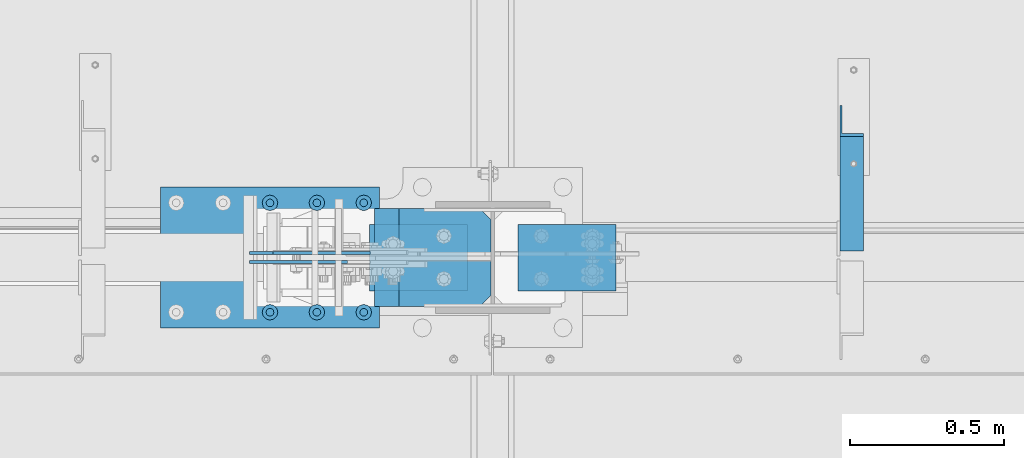
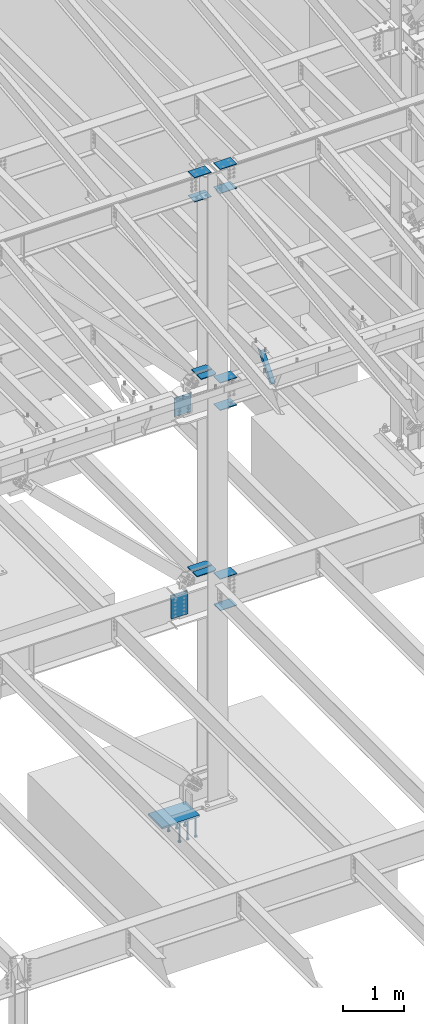
# One storey, part 841 of 1179: 22 beams, 1 member, 6 elements without a shape of their own.
"""IFC2X3 building model written with IfcOpenShell, lengths in millimetres."""

from ifc_helpers import new_model, si_unit, frame, origin_with_axes, place, context, subcontext, project, spatial, faceted_brep, material, type_object, element, aggregate, save


model = new_model("IFC2X3")

# Units and contexts
model_context = context("Model", 3, precision=1e-05, world=origin_with_axes())
body_context = subcontext(model_context, "Body", "Model", "MODEL_VIEW")
ifc_project = project(units=[si_unit("LENGTHUNIT", "METRE", prefix="MILLI"), si_unit("AREAUNIT", "SQUARE_METRE"), si_unit("VOLUMEUNIT", "CUBIC_METRE"), si_unit("MASSUNIT", "GRAM", prefix="KILO"), si_unit("TIMEUNIT", "SECOND"), si_unit("PLANEANGLEUNIT", "RADIAN"), si_unit("SOLIDANGLEUNIT", "STERADIAN"), si_unit("THERMODYNAMICTEMPERATUREUNIT", "DEGREE_CELSIUS"), si_unit("LUMINOUSINTENSITYUNIT", "LUMEN")], contexts=[model_context])

# Site, building, storey
site_placement = place(None, origin_with_axes())
site = spatial("IfcSite", under=ifc_project, at=site_placement, CompositionType="ELEMENT")
building_placement = place(site_placement, origin_with_axes())
building = spatial("IfcBuilding", under=site, at=building_placement, Name="Undefined", CompositionType="ELEMENT")
storey_placement = place(building_placement, origin_with_axes())
storey = spatial("IfcBuildingStorey", under=building, at=storey_placement, Name="Undefined", CompositionType="ELEMENT", Elevation=0.0)

# Assembly, member
assembly_1_placement = place(storey_placement, origin_with_axes())
assembly_1 = element("IfcElementAssembly", 1, at=assembly_1_placement, inside=storey, Name="ANGLE", AssemblyPlace="NOTDEFINED", PredefinedType="RIGID_FRAME")
ifc_material_1 = material(Name="STEEL/A36")
member_type = type_object("IfcMemberType", Name="L3X3X1/4", PredefinedType="NOTDEFINED")
member_placement = place(assembly_1_placement, frame((17626.0124995918, 27508.2, 8013.7), z_axis=(0.0, 0.7672237920886, -0.641379492074067), x_axis=(0.0, -0.641379492074066, -0.767223792088601)))
member = element("IfcMember", 2, at=member_placement, type_object=member_type, material=ifc_material_1, Name="ANGLE", ObjectType="L3X3X1/4", context=body_context, shape_type="Brep", body=[
    faceted_brep([(52.5421123063024, 38.0999999999985, -38.0999999999967), (-11.159141226166, 38.0999999999985, 38.1000000000095), (634.651401994255, 38.0999999999985, 38.1000000003041), (634.651401994233, 38.0999999999985, -38.0999999997293), (-11.159141226166, 31.75, 38.1000000000095), (634.651401994255, 31.75, 38.1000000003041), (47.2336745119283, 31.75, -31.7499999999982), (634.651401994237, 31.75, -31.7499999997272), (47.2336745119283, -38.0999999999985, -31.7499999999982), (634.651401994237, -38.0999999999985, -31.7499999997272), (52.5421123063024, -38.0999999999985, -38.0999999999967), (634.651401994233, -38.0999999999985, -38.0999999997293)], [[[0, 1, 2, 3]], [[1, 4, 5, 2]], [[4, 6, 7, 5]], [[6, 8, 9, 7]], [[8, 10, 11, 9]], [[10, 0, 3, 11]], [[5, 7, 9, 11, 3, 2]], [[10, 8, 6, 4, 1, 0]]]),
])
aggregate(assembly_1, [member])

# Assembly, beams
assembly_2_placement = place(storey_placement, origin_with_axes())
assembly_2 = element("IfcElementAssembly", 3, at=assembly_2_placement, inside=storey, Name="COLUMN", AssemblyPlace="NOTDEFINED", PredefinedType="RIGID_FRAME")
ifc_material_2 = material(Name="STEEL/A572-GR.50")
beam_type_1 = type_object("IfcBeamType", PredefinedType="NOTDEFINED")
beam_1_placement = place(assembly_2_placement, frame((16376.65, 27051.0, 11796.3156250357), z_axis=(0.0, -1.0, 0.0), x_axis=(-1.0, 0.0, 0.0)))
beam_1 = element("IfcBeam", 4, at=beam_1_placement, type_object=beam_type_1, material=ifc_material_2, Name="PLATE", context=body_context, shape_type="Brep", body=[
    faceted_brep([(0.0, 6.35000000000036, -107.949999999997), (0.0, 6.35000000000036, 107.949999999997), (317.5, 6.35000000000036, 107.949999999997), (317.5, 6.35000000000036, -107.949999999997), (0.0, -6.35000000000036, 107.949999999997), (317.5, -6.35000000000036, 107.949999999997), (0.0, -6.35000000000036, -107.949999999997), (317.5, -6.35000000000036, -107.949999999997)], [[[0, 1, 2, 3]], [[1, 4, 5, 2]], [[4, 6, 7, 5]], [[6, 0, 3, 7]], [[5, 7, 3, 2]], [[6, 4, 1, 0]]]),
])
beam_2_placement = place(assembly_2_placement, frame((16376.65, 27051.0, 12275.7406249372), z_axis=(0.0, -1.0, 0.0), x_axis=(-1.0, 0.0, 0.0)))
beam_2 = element("IfcBeam", 5, at=beam_2_placement, type_object=beam_type_1, material=ifc_material_2, Name="PLATE", context=body_context, shape_type="Brep", body=[
    faceted_brep([(0.0, 6.35000000000036, -107.949999999997), (0.0, 6.35000000000036, 107.949999999997), (317.5, 6.35000000000036, 107.949999999997), (317.5, 6.35000000000036, -107.949999999997), (0.0, -6.35000000000036, 107.949999999997), (317.5, -6.35000000000036, 107.949999999997), (0.0, -6.35000000000036, -107.949999999997), (317.5, -6.35000000000036, -107.949999999997)], [[[0, 1, 2, 3]], [[1, 4, 5, 2]], [[4, 6, 7, 5]], [[6, 0, 3, 7]], [[5, 7, 3, 2]], [[6, 4, 1, 0]]]),
])
beam_3_placement = place(assembly_2_placement, frame((16541.7500000265, 27051.0, 11796.3156249387), z_axis=(0.0, -1.0, 0.0), x_axis=(1.0, 0.0, 0.0)))
beam_3 = element("IfcBeam", 6, at=beam_3_placement, type_object=beam_type_1, material=ifc_material_2, Name="PLATE", context=body_context, shape_type="Brep", body=[
    faceted_brep([(0.0, 6.35000000000036, -107.949999999997), (0.0, 6.35000000000036, 107.949999999997), (317.5, 6.35000000000036, 107.949999999997), (317.5, 6.35000000000036, -107.949999999997), (0.0, -6.35000000000036, 107.949999999997), (317.5, -6.35000000000036, 107.949999999997), (0.0, -6.35000000000036, -107.949999999997), (317.5, -6.35000000000036, -107.949999999997)], [[[0, 1, 2, 3]], [[1, 4, 5, 2]], [[4, 6, 7, 5]], [[6, 0, 3, 7]], [[5, 7, 3, 2]], [[6, 4, 1, 0]]]),
])
beam_4_placement = place(assembly_2_placement, frame((16541.7500000265, 27051.0, 12275.7406248401), z_axis=(0.0, -1.0, 0.0), x_axis=(1.0, 0.0, 0.0)))
beam_4 = element("IfcBeam", 7, at=beam_4_placement, type_object=beam_type_1, material=ifc_material_2, Name="PLATE", context=body_context, shape_type="Brep", body=[
    faceted_brep([(0.0, 6.35000000000036, -107.949999999997), (0.0, 6.35000000000036, 107.949999999997), (317.5, 6.35000000000036, 107.949999999997), (317.5, 6.35000000000036, -107.949999999997), (0.0, -6.35000000000036, 107.949999999997), (317.5, -6.35000000000036, 107.949999999997), (0.0, -6.35000000000036, -107.949999999997), (317.5, -6.35000000000036, -107.949999999997)], [[[0, 1, 2, 3]], [[1, 4, 5, 2]], [[4, 6, 7, 5]], [[6, 0, 3, 7]], [[5, 7, 3, 2]], [[6, 4, 1, 0]]]),
])
beam_5_placement = place(assembly_2_placement, frame((16541.7500046069, 27051.0, 7473.95000014484), z_axis=(0.0, -1.0, 0.0), x_axis=(1.0, 0.0, 0.0)))
beam_5 = element("IfcBeam", 8, at=beam_5_placement, type_object=beam_type_1, material=ifc_material_2, Name="PLATE", context=body_context, shape_type="Brep", body=[
    faceted_brep([(0.0, 6.35000000000036, -107.949999999997), (0.0, 6.35000000000036, 107.949999999997), (317.5, 6.35000000000036, 107.949999999997), (317.5, 6.35000000000036, -107.949999999997), (0.0, -6.35000000000036, 107.949999999997), (317.5, -6.35000000000036, 107.949999999997), (0.0, -6.35000000000036, -107.949999999997), (317.5, -6.35000000000036, -107.949999999997)], [[[0, 1, 2, 3]], [[1, 4, 5, 2]], [[4, 6, 7, 5]], [[6, 0, 3, 7]], [[5, 7, 3, 2]], [[6, 4, 1, 0]]]),
])
beam_6_placement = place(assembly_2_placement, frame((16541.7500040853, 27051.0, 8020.04999989655), z_axis=(0.0, -1.0, 0.0), x_axis=(1.0, 0.0, 0.0)))
beam_6 = element("IfcBeam", 9, at=beam_6_placement, type_object=beam_type_1, material=ifc_material_2, Name="PLATE", context=body_context, shape_type="Brep", body=[
    faceted_brep([(0.0, 6.35000000000036, -107.949999999997), (0.0, 6.35000000000036, 107.949999999997), (317.5, 6.35000000000036, 107.949999999997), (317.5, 6.35000000000036, -107.949999999997), (0.0, -6.35000000000036, 107.949999999997), (317.5, -6.35000000000036, 107.949999999997), (0.0, -6.35000000000036, -107.949999999997), (317.5, -6.35000000000036, -107.949999999997)], [[[0, 1, 2, 3]], [[1, 4, 5, 2]], [[4, 6, 7, 5]], [[6, 0, 3, 7]], [[5, 7, 3, 2]], [[6, 4, 1, 0]]]),
])
beam_7_placement = place(assembly_2_placement, frame((16541.7500078275, 27051.0, 3482.97499616502), z_axis=(0.0, -1.0, 0.0), x_axis=(1.0, 0.0, 0.0)))
beam_7 = element("IfcBeam", 10, at=beam_7_placement, type_object=beam_type_1, material=ifc_material_2, Name="PLATE", context=body_context, shape_type="Brep", body=[
    faceted_brep([(0.0, 6.35000000000036, -107.949999999997), (0.0, 6.35000000000036, 107.949999999997), (317.5, 6.35000000000036, 107.949999999997), (317.5, 6.35000000000036, -107.949999999997), (0.0, -6.35000000000036, 107.949999999997), (317.5, -6.35000000000036, 107.949999999997), (0.0, -6.35000000000036, -107.949999999997), (317.5, -6.35000000000036, -107.949999999997)], [[[0, 1, 2, 3]], [[1, 4, 5, 2]], [[4, 6, 7, 5]], [[6, 0, 3, 7]], [[5, 7, 3, 2]], [[6, 4, 1, 0]]]),
])
beam_8_placement = place(assembly_2_placement, frame((16541.7500078275, 27051.0, 4108.44999990144), z_axis=(0.0, -1.0, 0.0), x_axis=(1.0, 0.0, 0.0)))
beam_8 = element("IfcBeam", 11, at=beam_8_placement, type_object=beam_type_1, material=ifc_material_2, Name="PLATE", context=body_context, shape_type="Brep", body=[
    faceted_brep([(0.0, 6.35000000000036, -107.949999999997), (0.0, 6.35000000000036, 107.949999999997), (317.5, 6.35000000000036, 107.949999999997), (317.5, 6.35000000000036, -107.949999999997), (0.0, -6.35000000000036, 107.949999999997), (317.5, -6.35000000000036, 107.949999999997), (0.0, -6.35000000000036, -107.949999999997), (317.5, -6.35000000000036, -107.949999999997)], [[[0, 1, 2, 3]], [[1, 4, 5, 2]], [[4, 6, 7, 5]], [[6, 0, 3, 7]], [[5, 7, 3, 2]], [[6, 4, 1, 0]]]),
])

# Assembly, beam
assembly_3_placement = place(storey_placement, origin_with_axes())
assembly_3 = element("IfcElementAssembly", 12, at=assembly_3_placement, inside=storey, Name="PLATE", AssemblyPlace="NOTDEFINED", PredefinedType="RIGID_FRAME")
beam_type_2 = type_object("IfcBeamType", PredefinedType="NOTDEFINED")
beam_9_placement = place(assembly_3_placement, frame((16062.3160798978, 27065.2872136118, 7739.06249999967), z_axis=(0.0, 0.0, -1.0), x_axis=(-1.0, 0.0, 0.0)))
beam_9 = element("IfcBeam", 13, at=beam_9_placement, type_object=beam_type_2, material=ifc_material_2, Name="PLATE", context=body_context, shape_type="Brep", body=[
    faceted_brep([(0.0, 4.76249999999709, -190.5), (0.0, 4.76249999999709, 190.5), (317.499999999995, 4.76250000000073, 190.500000000051), (317.500000000042, 4.76250000000073, -190.499999999973), (0.0, -4.76249999999709, 190.5), (317.499999999995, -4.76250000000073, 190.500000000051), (0.0, -4.76249999999709, -190.5), (317.500000000042, -4.76250000000073, -190.499999999973)], [[[0, 1, 2, 3]], [[1, 4, 5, 2]], [[4, 6, 7, 5]], [[6, 0, 3, 7]], [[5, 7, 3, 2]], [[6, 4, 1, 0]]]),
])
aggregate(assembly_3, [beam_9])

assembly_4_placement = place(storey_placement, origin_with_axes())
assembly_4 = element("IfcElementAssembly", 14, at=assembly_4_placement, inside=storey, Name="PLATE", AssemblyPlace="NOTDEFINED", PredefinedType="RIGID_FRAME")
beam_10_placement = place(assembly_4_placement, frame((15668.9879892222, 27036.7125, 3790.94999999901), z_axis=(0.0, 0.0, -1.0), x_axis=(1.0, 0.0, 0.0)))
beam_10 = element("IfcBeam", 15, at=beam_10_placement, type_object=beam_type_2, material=ifc_material_2, Name="PLATE", context=body_context, shape_type="Brep", body=[
    faceted_brep([(0.0, 4.76250000000073, -228.6), (0.0, 4.76249999999999, 228.6), (317.5, 4.76250000000073, 228.6), (317.5, 4.76250000000073, -228.6), (0.0, -4.76249999999999, 228.6), (317.5, -4.76250000000073, 228.6), (0.0, -4.76250000000073, -228.6), (317.5, -4.76250000000073, -228.6)], [[[0, 1, 2, 3]], [[1, 4, 5, 2]], [[4, 6, 7, 5]], [[6, 0, 3, 7]], [[5, 7, 3, 2]], [[6, 4, 1, 0]]]),
])
aggregate(assembly_4, [beam_10])

assembly_5_placement = place(storey_placement, origin_with_axes())
assembly_5 = element("IfcElementAssembly", 16, at=assembly_5_placement, inside=storey, Name="PLATE", AssemblyPlace="NOTDEFINED", PredefinedType="RIGID_FRAME")
beam_11_placement = place(assembly_5_placement, frame((15986.4879892222, 27065.2872136118, 3790.94999999901), z_axis=(0.0, 0.0, -1.0), x_axis=(-1.0, 0.0, 0.0)))
beam_11 = element("IfcBeam", 17, at=beam_11_placement, type_object=beam_type_2, material=ifc_material_2, Name="PLATE", context=body_context, shape_type="Brep", body=[
    faceted_brep([(0.0, 4.76250000000073, -228.6), (0.0, 4.76249999999999, 228.6), (317.5, 4.76250000000073, 228.6), (317.5, 4.76250000000073, -228.6), (0.0, -4.76249999999999, 228.6), (317.5, -4.76250000000073, 228.6), (0.0, -4.76250000000073, -228.6), (317.5, -4.76250000000073, -228.6)], [[[0, 1, 2, 3]], [[1, 4, 5, 2]], [[4, 6, 7, 5]], [[6, 0, 3, 7]], [[5, 7, 3, 2]], [[6, 4, 1, 0]]]),
])
aggregate(assembly_5, [beam_11])

# Beam
beam_type_3 = type_object("IfcBeamType", PredefinedType="NOTDEFINED")
beam_12_placement = place(assembly_2_placement, frame((16452.8300674267, 26966.0685, 4353.36123523171), z_axis=(0.0, 1.0, 0.0), x_axis=(-1.0, 0.0, 0.0)))
beam_12 = element("IfcBeam", 18, at=beam_12_placement, type_object=beam_type_3, material=ifc_material_2, Name="PLATE", context=body_context, shape_type="Brep", body=[
    faceted_brep([(34.9249999999993, -9.52499999999964, -73.8189999999995), (0.0, -9.52499999999964, -38.8940000000002), (0.0, 9.52499999999964, -38.8940000000002), (34.9249999999993, 9.52499999999964, -73.8189999999995), (0.0, 9.52499999999964, 73.8189999999995), (377.164906529422, 9.52499999999964, 73.8189999999995), (377.164906529422, 9.52499999999964, -73.8189999999995), (0.0, -9.52499999999964, 73.8189999999995), (377.164906529422, -9.52499999999964, 73.8189999999995), (377.164906529422, -9.52499999999964, -73.8189999999995)], [[[0, 1, 2, 3]], [[4, 5, 6, 3, 2]], [[4, 7, 8, 5]], [[9, 8, 7, 1, 0]], [[6, 9, 0, 3]], [[8, 9, 6, 5]], [[7, 4, 2, 1]]]),
])

beam_13_placement = place(assembly_2_placement, frame((16452.8300674267, 27135.9315, 4353.36123523171), z_axis=(0.0, -1.0, 0.0), x_axis=(-1.0, 0.0, 0.0)))
beam_13 = element("IfcBeam", 19, at=beam_13_placement, type_object=beam_type_3, material=ifc_material_2, Name="PLATE", context=body_context, shape_type="Brep", body=[
    faceted_brep([(34.9249999999993, -9.52499999999964, -73.8189999999995), (0.0, -9.52499999999964, -38.8940000000002), (0.0, 9.52499999999964, -38.8940000000002), (34.9249999999993, 9.52499999999964, -73.8189999999995), (0.0, 9.52499999999964, 73.8189999999995), (377.164906529422, 9.52499999999964, 73.8189999999995), (377.164906529422, 9.52499999999964, -73.8189999999995), (0.0, -9.52499999999964, 73.8189999999995), (377.164906529422, -9.52499999999964, 73.8189999999995), (377.164906529422, -9.52499999999964, -73.8189999999995)], [[[0, 1, 2, 3]], [[4, 5, 6, 3, 2]], [[4, 7, 8, 5]], [[9, 8, 7, 1, 0]], [[6, 9, 0, 3]], [[8, 9, 6, 5]], [[7, 4, 2, 1]]]),
])

beam_14_placement = place(assembly_2_placement, frame((16154.010667193, 26966.0685, 8260.28541437128), z_axis=(0.0, -1.0, 0.0), x_axis=(1.0, 0.0, 0.0)))
beam_14 = element("IfcBeam", 20, at=beam_14_placement, type_object=beam_type_3, material=ifc_material_2, Name="PLATE", context=body_context, shape_type="Brep", body=[
    faceted_brep([(298.839332807032, 9.52499999999964, 38.8940000000002), (263.914332807033, 9.52499999999964, 73.8189999999995), (263.914332807033, -9.52499999999964, 73.8189999999995), (298.839332807032, -9.52499999999964, 38.8940000000002), (298.839332807032, 9.52499999999964, -73.8189999999995), (0.0, 9.52499999999964, -73.8189999999995), (0.0, 9.52499999999964, 73.8189999999995), (0.0, -9.52499999999964, 73.8189999999995), (0.0, -9.52499999999964, -73.8189999999995), (298.839332807032, -9.52499999999964, -73.8189999999995)], [[[0, 1, 2, 3]], [[4, 5, 6, 1, 0]], [[6, 7, 2, 1]], [[7, 8, 9, 3, 2]], [[8, 5, 4, 9]], [[9, 4, 0, 3]], [[8, 7, 6, 5]]]),
])

beam_15_placement = place(assembly_2_placement, frame((16154.010667193, 27135.9315, 8260.28541437128), z_axis=(0.0, 1.0, 0.0), x_axis=(1.0, 0.0, 0.0)))
beam_15 = element("IfcBeam", 21, at=beam_15_placement, type_object=beam_type_3, material=ifc_material_2, Name="PLATE", context=body_context, shape_type="Brep", body=[
    faceted_brep([(298.839332807032, 9.52499999999964, 38.8940000000002), (263.914332807033, 9.52499999999964, 73.8189999999995), (263.914332807033, -9.52499999999964, 73.8189999999995), (298.839332807032, -9.52499999999964, 38.8940000000002), (298.839332807032, 9.52499999999964, -73.8189999999995), (0.0, 9.52499999999964, -73.8189999999995), (0.0, 9.52499999999964, 73.8189999999995), (0.0, -9.52499999999964, 73.8189999999995), (0.0, -9.52499999999964, -73.8189999999995), (298.839332807032, -9.52499999999964, -73.8189999999995)], [[[0, 1, 2, 3]], [[4, 5, 6, 1, 0]], [[6, 7, 2, 1]], [[7, 8, 9, 3, 2]], [[8, 5, 4, 9]], [[9, 4, 0, 3]], [[8, 7, 6, 5]]]),
])

aggregate(assembly_2, [beam_12, beam_13, beam_1, beam_2, beam_3, beam_4, beam_14, beam_15, beam_5, beam_6, beam_7, beam_8])

# Assembly, beams
assembly_6_placement = place(storey_placement, origin_with_axes())
assembly_6 = element("IfcElementAssembly", 22, at=assembly_6_placement, inside=storey, Name="EMBED_PLATE", AssemblyPlace="NOTDEFINED", PredefinedType="RIGID_FRAME")
ifc_material_3 = material(Name="STEEL/A108")
beam_type_4 = type_object("IfcBeamType", Name="STUD_1-DIA", PredefinedType="NOTDEFINED")
beam_16_placement = place(assembly_6_placement, frame((16040.1, 26873.2, -393.700000000001), z_axis=(-1.0, 0.0, 0.0), x_axis=(0.0, 0.0, -1.0)))
beam_16 = element("IfcBeam", 23, at=beam_16_placement, type_object=beam_type_4, material=ifc_material_3, Name="STUD", ObjectType="STUD_1-DIA", context=body_context, shape_type="Brep", body=[
    faceted_brep([(0.0, -12.7, 0.0), (0.0, -11.0, -6.34999990463257), (382.016, -11.0, -6.34999990463257), (382.016, -12.6999998092651, 0.0), (0.0, -6.34999990463257, -11.0), (382.016, -6.34999990463257, -11.0), (0.0, 0.0, -12.6999998092651), (382.016, 0.0, -12.6999998092651), (0.0, 6.34999990463257, -11.0), (382.016, 6.34999990463257, -11.0), (0.0, 11.0, -6.34999990463257), (382.016, 11.0, -6.34999990463257), (0.0, 12.7, 0.0), (382.016, 12.6999998092651, 0.0), (0.0, 11.0, 6.34999990463257), (382.016, 11.0, 6.34999990463257), (0.0, 6.34999990463257, 11.0), (382.016, 6.34999990463257, 11.0), (0.0, 0.0, 12.6999998092651), (382.016, 0.0, 12.6999998092651), (0.0, -6.34999990463257, 11.0), (382.016, -6.34999990463257, 11.0), (0.0, -11.0, 6.34999990463257), (382.016, -11.0, 6.34999990463257), (386.08, -22.0, -12.6999998092651), (386.08, -25.3999996185303, 0.0), (386.08, -12.6999998092651, -22.0), (386.08, 0.0, -25.3999996185303), (386.08, 12.6999998092651, -22.0), (386.08, 22.0, -12.6999998092651), (386.08, 25.3999996185303, 0.0), (386.08, 22.0, 12.6999998092651), (386.08, 12.6999998092651, 22.0), (386.08, 0.0, 25.3999996185303), (386.08, -12.6999998092651, 22.0), (386.08, -22.0, 12.6999998092651), (406.4, -22.0, -12.6999998092651), (406.4, -25.3999996185303, 0.0), (406.4, -12.6999998092651, -22.0), (406.4, 0.0, -25.3999996185303), (406.4, 12.6999998092651, -22.0), (406.4, 22.0, -12.6999998092651), (406.4, 25.3999996185303, 0.0), (406.4, 22.0, 12.6999998092651), (406.4, 12.6999998092651, 22.0), (406.4, 0.0, 25.3999996185303), (406.4, -12.6999998092651, 22.0), (406.4, -22.0, 12.6999998092651)], [[[0, 1, 2, 3]], [[1, 4, 5, 2]], [[4, 6, 7, 5]], [[6, 8, 9, 7]], [[8, 10, 11, 9]], [[10, 12, 13, 11]], [[12, 14, 15, 13]], [[14, 16, 17, 15]], [[16, 18, 19, 17]], [[18, 20, 21, 19]], [[20, 22, 23, 21]], [[22, 0, 3, 23]], [[22, 20, 18, 16, 14, 12, 10, 8, 6, 4, 1, 0]], [[3, 2, 24, 25]], [[2, 5, 26, 24]], [[5, 7, 27, 26]], [[7, 9, 28, 27]], [[9, 11, 29, 28]], [[11, 13, 30, 29]], [[13, 15, 31, 30]], [[15, 17, 32, 31]], [[17, 19, 33, 32]], [[19, 21, 34, 33]], [[21, 23, 35, 34]], [[23, 3, 25, 35]], [[25, 24, 36, 37]], [[24, 26, 38, 36]], [[26, 27, 39, 38]], [[27, 28, 40, 39]], [[28, 29, 41, 40]], [[29, 30, 42, 41]], [[30, 31, 43, 42]], [[31, 32, 44, 43]], [[32, 33, 45, 44]], [[33, 34, 46, 45]], [[34, 35, 47, 46]], [[35, 25, 37, 47]], [[38, 39, 40, 41, 42, 43, 44, 45, 46, 47, 37, 36]]]),
])
beam_17_placement = place(assembly_6_placement, frame((16040.1, 27228.8, -393.700000000001), z_axis=(-1.0, 0.0, 0.0), x_axis=(0.0, 0.0, -1.0)))
beam_17 = element("IfcBeam", 24, at=beam_17_placement, type_object=beam_type_4, material=ifc_material_3, Name="STUD", ObjectType="STUD_1-DIA", context=body_context, shape_type="Brep", body=[
    faceted_brep([(0.0, -12.7, 0.0), (0.0, -11.0, -6.34999990463257), (382.016, -11.0, -6.34999990463257), (382.016, -12.6999998092651, 0.0), (0.0, -6.34999990463257, -11.0), (382.016, -6.34999990463257, -11.0), (0.0, 0.0, -12.6999998092651), (382.016, 0.0, -12.6999998092651), (0.0, 6.34999990463257, -11.0), (382.016, 6.34999990463257, -11.0), (0.0, 11.0, -6.34999990463257), (382.016, 11.0, -6.34999990463257), (0.0, 12.7, 0.0), (382.016, 12.6999998092651, 0.0), (0.0, 11.0, 6.34999990463257), (382.016, 11.0, 6.34999990463257), (0.0, 6.34999990463257, 11.0), (382.016, 6.34999990463257, 11.0), (0.0, 0.0, 12.6999998092651), (382.016, 0.0, 12.6999998092651), (0.0, -6.34999990463257, 11.0), (382.016, -6.34999990463257, 11.0), (0.0, -11.0, 6.34999990463257), (382.016, -11.0, 6.34999990463257), (386.08, -22.0, -12.6999998092651), (386.08, -25.3999996185303, 0.0), (386.08, -12.6999998092651, -22.0), (386.08, 0.0, -25.3999996185303), (386.08, 12.6999998092651, -22.0), (386.08, 22.0, -12.6999998092651), (386.08, 25.3999996185303, 0.0), (386.08, 22.0, 12.6999998092651), (386.08, 12.6999998092651, 22.0), (386.08, 0.0, 25.3999996185303), (386.08, -12.6999998092651, 22.0), (386.08, -22.0, 12.6999998092651), (406.4, -22.0, -12.6999998092651), (406.4, -25.3999996185303, 0.0), (406.4, -12.6999998092651, -22.0), (406.4, 0.0, -25.3999996185303), (406.4, 12.6999998092651, -22.0), (406.4, 22.0, -12.6999998092651), (406.4, 25.3999996185303, 0.0), (406.4, 22.0, 12.6999998092651), (406.4, 12.6999998092651, 22.0), (406.4, 0.0, 25.3999996185303), (406.4, -12.6999998092651, 22.0), (406.4, -22.0, 12.6999998092651)], [[[0, 1, 2, 3]], [[1, 4, 5, 2]], [[4, 6, 7, 5]], [[6, 8, 9, 7]], [[8, 10, 11, 9]], [[10, 12, 13, 11]], [[12, 14, 15, 13]], [[14, 16, 17, 15]], [[16, 18, 19, 17]], [[18, 20, 21, 19]], [[20, 22, 23, 21]], [[22, 0, 3, 23]], [[22, 20, 18, 16, 14, 12, 10, 8, 6, 4, 1, 0]], [[3, 2, 24, 25]], [[2, 5, 26, 24]], [[5, 7, 27, 26]], [[7, 9, 28, 27]], [[9, 11, 29, 28]], [[11, 13, 30, 29]], [[13, 15, 31, 30]], [[15, 17, 32, 31]], [[17, 19, 33, 32]], [[19, 21, 34, 33]], [[21, 23, 35, 34]], [[23, 3, 25, 35]], [[25, 24, 36, 37]], [[24, 26, 38, 36]], [[26, 27, 39, 38]], [[27, 28, 40, 39]], [[28, 29, 41, 40]], [[29, 30, 42, 41]], [[30, 31, 43, 42]], [[31, 32, 44, 43]], [[32, 33, 45, 44]], [[33, 34, 46, 45]], [[34, 35, 47, 46]], [[35, 25, 37, 47]], [[38, 39, 40, 41, 42, 43, 44, 45, 46, 47, 37, 36]]]),
])
beam_18_placement = place(assembly_6_placement, frame((15735.3, 26873.2, -393.700000000001), z_axis=(-1.0, 0.0, 0.0), x_axis=(0.0, 0.0, -1.0)))
beam_18 = element("IfcBeam", 25, at=beam_18_placement, type_object=beam_type_4, material=ifc_material_3, Name="STUD", ObjectType="STUD_1-DIA", context=body_context, shape_type="Brep", body=[
    faceted_brep([(0.0, -12.7, 0.0), (0.0, -11.0, -6.34999990463257), (382.016, -11.0, -6.34999990463257), (382.016, -12.6999998092651, 0.0), (0.0, -6.34999990463257, -11.0), (382.016, -6.34999990463257, -11.0), (0.0, 0.0, -12.6999998092651), (382.016, 0.0, -12.6999998092651), (0.0, 6.34999990463257, -11.0), (382.016, 6.34999990463257, -11.0), (0.0, 11.0, -6.34999990463257), (382.016, 11.0, -6.34999990463257), (0.0, 12.7, 0.0), (382.016, 12.6999998092651, 0.0), (0.0, 11.0, 6.34999990463257), (382.016, 11.0, 6.34999990463257), (0.0, 6.34999990463257, 11.0), (382.016, 6.34999990463257, 11.0), (0.0, 0.0, 12.6999998092651), (382.016, 0.0, 12.6999998092651), (0.0, -6.34999990463257, 11.0), (382.016, -6.34999990463257, 11.0), (0.0, -11.0, 6.34999990463257), (382.016, -11.0, 6.34999990463257), (386.08, -22.0, -12.6999998092651), (386.08, -25.3999996185303, 0.0), (386.08, -12.6999998092651, -22.0), (386.08, 0.0, -25.3999996185303), (386.08, 12.6999998092651, -22.0), (386.08, 22.0, -12.6999998092651), (386.08, 25.3999996185303, 0.0), (386.08, 22.0, 12.6999998092651), (386.08, 12.6999998092651, 22.0), (386.08, 0.0, 25.3999996185303), (386.08, -12.6999998092651, 22.0), (386.08, -22.0, 12.6999998092651), (406.4, -22.0, -12.6999998092651), (406.4, -25.3999996185303, 0.0), (406.4, -12.6999998092651, -22.0), (406.4, 0.0, -25.3999996185303), (406.4, 12.6999998092651, -22.0), (406.4, 22.0, -12.6999998092651), (406.4, 25.3999996185303, 0.0), (406.4, 22.0, 12.6999998092651), (406.4, 12.6999998092651, 22.0), (406.4, 0.0, 25.3999996185303), (406.4, -12.6999998092651, 22.0), (406.4, -22.0, 12.6999998092651)], [[[0, 1, 2, 3]], [[1, 4, 5, 2]], [[4, 6, 7, 5]], [[6, 8, 9, 7]], [[8, 10, 11, 9]], [[10, 12, 13, 11]], [[12, 14, 15, 13]], [[14, 16, 17, 15]], [[16, 18, 19, 17]], [[18, 20, 21, 19]], [[20, 22, 23, 21]], [[22, 0, 3, 23]], [[22, 20, 18, 16, 14, 12, 10, 8, 6, 4, 1, 0]], [[3, 2, 24, 25]], [[2, 5, 26, 24]], [[5, 7, 27, 26]], [[7, 9, 28, 27]], [[9, 11, 29, 28]], [[11, 13, 30, 29]], [[13, 15, 31, 30]], [[15, 17, 32, 31]], [[17, 19, 33, 32]], [[19, 21, 34, 33]], [[21, 23, 35, 34]], [[23, 3, 25, 35]], [[25, 24, 36, 37]], [[24, 26, 38, 36]], [[26, 27, 39, 38]], [[27, 28, 40, 39]], [[28, 29, 41, 40]], [[29, 30, 42, 41]], [[30, 31, 43, 42]], [[31, 32, 44, 43]], [[32, 33, 45, 44]], [[33, 34, 46, 45]], [[34, 35, 47, 46]], [[35, 25, 37, 47]], [[38, 39, 40, 41, 42, 43, 44, 45, 46, 47, 37, 36]]]),
])
beam_19_placement = place(assembly_6_placement, frame((15887.7, 26873.2, -393.700000000001), z_axis=(-1.0, 0.0, 0.0), x_axis=(0.0, 0.0, -1.0)))
beam_19 = element("IfcBeam", 26, at=beam_19_placement, type_object=beam_type_4, material=ifc_material_3, Name="STUD", ObjectType="STUD_1-DIA", context=body_context, shape_type="Brep", body=[
    faceted_brep([(0.0, -12.7, 0.0), (0.0, -11.0, -6.34999990463257), (382.016, -11.0, -6.34999990463257), (382.016, -12.6999998092651, 0.0), (0.0, -6.34999990463257, -11.0), (382.016, -6.34999990463257, -11.0), (0.0, 0.0, -12.6999998092651), (382.016, 0.0, -12.6999998092651), (0.0, 6.34999990463257, -11.0), (382.016, 6.34999990463257, -11.0), (0.0, 11.0, -6.34999990463257), (382.016, 11.0, -6.34999990463257), (0.0, 12.7, 0.0), (382.016, 12.6999998092651, 0.0), (0.0, 11.0, 6.34999990463257), (382.016, 11.0, 6.34999990463257), (0.0, 6.34999990463257, 11.0), (382.016, 6.34999990463257, 11.0), (0.0, 0.0, 12.6999998092651), (382.016, 0.0, 12.6999998092651), (0.0, -6.34999990463257, 11.0), (382.016, -6.34999990463257, 11.0), (0.0, -11.0, 6.34999990463257), (382.016, -11.0, 6.34999990463257), (386.08, -22.0, -12.6999998092651), (386.08, -25.3999996185303, 0.0), (386.08, -12.6999998092651, -22.0), (386.08, 0.0, -25.3999996185303), (386.08, 12.6999998092651, -22.0), (386.08, 22.0, -12.6999998092651), (386.08, 25.3999996185303, 0.0), (386.08, 22.0, 12.6999998092651), (386.08, 12.6999998092651, 22.0), (386.08, 0.0, 25.3999996185303), (386.08, -12.6999998092651, 22.0), (386.08, -22.0, 12.6999998092651), (406.4, -22.0, -12.6999998092651), (406.4, -25.3999996185303, 0.0), (406.4, -12.6999998092651, -22.0), (406.4, 0.0, -25.3999996185303), (406.4, 12.6999998092651, -22.0), (406.4, 22.0, -12.6999998092651), (406.4, 25.3999996185303, 0.0), (406.4, 22.0, 12.6999998092651), (406.4, 12.6999998092651, 22.0), (406.4, 0.0, 25.3999996185303), (406.4, -12.6999998092651, 22.0), (406.4, -22.0, 12.6999998092651)], [[[0, 1, 2, 3]], [[1, 4, 5, 2]], [[4, 6, 7, 5]], [[6, 8, 9, 7]], [[8, 10, 11, 9]], [[10, 12, 13, 11]], [[12, 14, 15, 13]], [[14, 16, 17, 15]], [[16, 18, 19, 17]], [[18, 20, 21, 19]], [[20, 22, 23, 21]], [[22, 0, 3, 23]], [[22, 20, 18, 16, 14, 12, 10, 8, 6, 4, 1, 0]], [[3, 2, 24, 25]], [[2, 5, 26, 24]], [[5, 7, 27, 26]], [[7, 9, 28, 27]], [[9, 11, 29, 28]], [[11, 13, 30, 29]], [[13, 15, 31, 30]], [[15, 17, 32, 31]], [[17, 19, 33, 32]], [[19, 21, 34, 33]], [[21, 23, 35, 34]], [[23, 3, 25, 35]], [[25, 24, 36, 37]], [[24, 26, 38, 36]], [[26, 27, 39, 38]], [[27, 28, 40, 39]], [[28, 29, 41, 40]], [[29, 30, 42, 41]], [[30, 31, 43, 42]], [[31, 32, 44, 43]], [[32, 33, 45, 44]], [[33, 34, 46, 45]], [[34, 35, 47, 46]], [[35, 25, 37, 47]], [[38, 39, 40, 41, 42, 43, 44, 45, 46, 47, 37, 36]]]),
])
beam_20_placement = place(assembly_6_placement, frame((15735.3, 27228.8, -393.700000000001), z_axis=(-1.0, 0.0, 0.0), x_axis=(0.0, 0.0, -1.0)))
beam_20 = element("IfcBeam", 27, at=beam_20_placement, type_object=beam_type_4, material=ifc_material_3, Name="STUD", ObjectType="STUD_1-DIA", context=body_context, shape_type="Brep", body=[
    faceted_brep([(0.0, -12.7, 0.0), (0.0, -11.0, -6.34999990463257), (382.016, -11.0, -6.34999990463257), (382.016, -12.6999998092651, 0.0), (0.0, -6.34999990463257, -11.0), (382.016, -6.34999990463257, -11.0), (0.0, 0.0, -12.6999998092651), (382.016, 0.0, -12.6999998092651), (0.0, 6.34999990463257, -11.0), (382.016, 6.34999990463257, -11.0), (0.0, 11.0, -6.34999990463257), (382.016, 11.0, -6.34999990463257), (0.0, 12.7, 0.0), (382.016, 12.6999998092651, 0.0), (0.0, 11.0, 6.34999990463257), (382.016, 11.0, 6.34999990463257), (0.0, 6.34999990463257, 11.0), (382.016, 6.34999990463257, 11.0), (0.0, 0.0, 12.6999998092651), (382.016, 0.0, 12.6999998092651), (0.0, -6.34999990463257, 11.0), (382.016, -6.34999990463257, 11.0), (0.0, -11.0, 6.34999990463257), (382.016, -11.0, 6.34999990463257), (386.08, -22.0, -12.6999998092651), (386.08, -25.3999996185303, 0.0), (386.08, -12.6999998092651, -22.0), (386.08, 0.0, -25.3999996185303), (386.08, 12.6999998092651, -22.0), (386.08, 22.0, -12.6999998092651), (386.08, 25.3999996185303, 0.0), (386.08, 22.0, 12.6999998092651), (386.08, 12.6999998092651, 22.0), (386.08, 0.0, 25.3999996185303), (386.08, -12.6999998092651, 22.0), (386.08, -22.0, 12.6999998092651), (406.4, -22.0, -12.6999998092651), (406.4, -25.3999996185303, 0.0), (406.4, -12.6999998092651, -22.0), (406.4, 0.0, -25.3999996185303), (406.4, 12.6999998092651, -22.0), (406.4, 22.0, -12.6999998092651), (406.4, 25.3999996185303, 0.0), (406.4, 22.0, 12.6999998092651), (406.4, 12.6999998092651, 22.0), (406.4, 0.0, 25.3999996185303), (406.4, -12.6999998092651, 22.0), (406.4, -22.0, 12.6999998092651)], [[[0, 1, 2, 3]], [[1, 4, 5, 2]], [[4, 6, 7, 5]], [[6, 8, 9, 7]], [[8, 10, 11, 9]], [[10, 12, 13, 11]], [[12, 14, 15, 13]], [[14, 16, 17, 15]], [[16, 18, 19, 17]], [[18, 20, 21, 19]], [[20, 22, 23, 21]], [[22, 0, 3, 23]], [[22, 20, 18, 16, 14, 12, 10, 8, 6, 4, 1, 0]], [[3, 2, 24, 25]], [[2, 5, 26, 24]], [[5, 7, 27, 26]], [[7, 9, 28, 27]], [[9, 11, 29, 28]], [[11, 13, 30, 29]], [[13, 15, 31, 30]], [[15, 17, 32, 31]], [[17, 19, 33, 32]], [[19, 21, 34, 33]], [[21, 23, 35, 34]], [[23, 3, 25, 35]], [[25, 24, 36, 37]], [[24, 26, 38, 36]], [[26, 27, 39, 38]], [[27, 28, 40, 39]], [[28, 29, 41, 40]], [[29, 30, 42, 41]], [[30, 31, 43, 42]], [[31, 32, 44, 43]], [[32, 33, 45, 44]], [[33, 34, 46, 45]], [[34, 35, 47, 46]], [[35, 25, 37, 47]], [[38, 39, 40, 41, 42, 43, 44, 45, 46, 47, 37, 36]]]),
])
beam_21_placement = place(assembly_6_placement, frame((15887.7, 27228.8, -393.700000000001), z_axis=(-1.0, 0.0, 0.0), x_axis=(0.0, 0.0, -1.0)))
beam_21 = element("IfcBeam", 28, at=beam_21_placement, type_object=beam_type_4, material=ifc_material_3, Name="STUD", ObjectType="STUD_1-DIA", context=body_context, shape_type="Brep", body=[
    faceted_brep([(0.0, -12.7, 0.0), (0.0, -11.0, -6.34999990463257), (382.016, -11.0, -6.34999990463257), (382.016, -12.6999998092651, 0.0), (0.0, -6.34999990463257, -11.0), (382.016, -6.34999990463257, -11.0), (0.0, 0.0, -12.6999998092651), (382.016, 0.0, -12.6999998092651), (0.0, 6.34999990463257, -11.0), (382.016, 6.34999990463257, -11.0), (0.0, 11.0, -6.34999990463257), (382.016, 11.0, -6.34999990463257), (0.0, 12.7, 0.0), (382.016, 12.6999998092651, 0.0), (0.0, 11.0, 6.34999990463257), (382.016, 11.0, 6.34999990463257), (0.0, 6.34999990463257, 11.0), (382.016, 6.34999990463257, 11.0), (0.0, 0.0, 12.6999998092651), (382.016, 0.0, 12.6999998092651), (0.0, -6.34999990463257, 11.0), (382.016, -6.34999990463257, 11.0), (0.0, -11.0, 6.34999990463257), (382.016, -11.0, 6.34999990463257), (386.08, -22.0, -12.6999998092651), (386.08, -25.3999996185303, 0.0), (386.08, -12.6999998092651, -22.0), (386.08, 0.0, -25.3999996185303), (386.08, 12.6999998092651, -22.0), (386.08, 22.0, -12.6999998092651), (386.08, 25.3999996185303, 0.0), (386.08, 22.0, 12.6999998092651), (386.08, 12.6999998092651, 22.0), (386.08, 0.0, 25.3999996185303), (386.08, -12.6999998092651, 22.0), (386.08, -22.0, 12.6999998092651), (406.4, -22.0, -12.6999998092651), (406.4, -25.3999996185303, 0.0), (406.4, -12.6999998092651, -22.0), (406.4, 0.0, -25.3999996185303), (406.4, 12.6999998092651, -22.0), (406.4, 22.0, -12.6999998092651), (406.4, 25.3999996185303, 0.0), (406.4, 22.0, 12.6999998092651), (406.4, 12.6999998092651, 22.0), (406.4, 0.0, 25.3999996185303), (406.4, -12.6999998092651, 22.0), (406.4, -22.0, 12.6999998092651)], [[[0, 1, 2, 3]], [[1, 4, 5, 2]], [[4, 6, 7, 5]], [[6, 8, 9, 7]], [[8, 10, 11, 9]], [[10, 12, 13, 11]], [[12, 14, 15, 13]], [[14, 16, 17, 15]], [[16, 18, 19, 17]], [[18, 20, 21, 19]], [[20, 22, 23, 21]], [[22, 0, 3, 23]], [[22, 20, 18, 16, 14, 12, 10, 8, 6, 4, 1, 0]], [[3, 2, 24, 25]], [[2, 5, 26, 24]], [[5, 7, 27, 26]], [[7, 9, 28, 27]], [[9, 11, 29, 28]], [[11, 13, 30, 29]], [[13, 15, 31, 30]], [[15, 17, 32, 31]], [[17, 19, 33, 32]], [[19, 21, 34, 33]], [[21, 23, 35, 34]], [[23, 3, 25, 35]], [[25, 24, 36, 37]], [[24, 26, 38, 36]], [[26, 27, 39, 38]], [[27, 28, 40, 39]], [[28, 29, 41, 40]], [[29, 30, 42, 41]], [[30, 31, 43, 42]], [[31, 32, 44, 43]], [[32, 33, 45, 44]], [[33, 34, 46, 45]], [[34, 35, 47, 46]], [[35, 25, 37, 47]], [[38, 39, 40, 41, 42, 43, 44, 45, 46, 47, 37, 36]]]),
])
beam_type_5 = type_object("IfcBeamType", PredefinedType="NOTDEFINED")
beam_22_placement = place(assembly_6_placement, frame((16090.9, 27051.0, -374.65), z_axis=(0.0, -1.0, 0.0), x_axis=(-1.0, 0.0, 0.0)))
beam_22 = element("IfcBeam", 29, at=beam_22_placement, type_object=beam_type_5, material=ifc_material_2, Name="EMBED_PLATE", context=body_context, shape_type="Brep", body=[
    faceted_brep([(0.0, 19.05, -228.6), (0.0, 19.05, 228.6), (711.200000000001, 19.05, 228.599999999999), (711.200000000001, 19.05, -228.599999999999), (0.0, -19.05, 228.6), (711.200000000001, -19.05, 228.599999999999), (0.0, -19.05, -228.6), (711.200000000001, -19.05, -228.599999999999)], [[[0, 1, 2, 3]], [[1, 4, 5, 2]], [[4, 6, 7, 5]], [[6, 0, 3, 7]], [[5, 7, 3, 2]], [[6, 4, 1, 0]]]),
])
aggregate(assembly_6, [beam_16, beam_17, beam_18, beam_19, beam_20, beam_21, beam_22])

save(model, "model.ifc")
